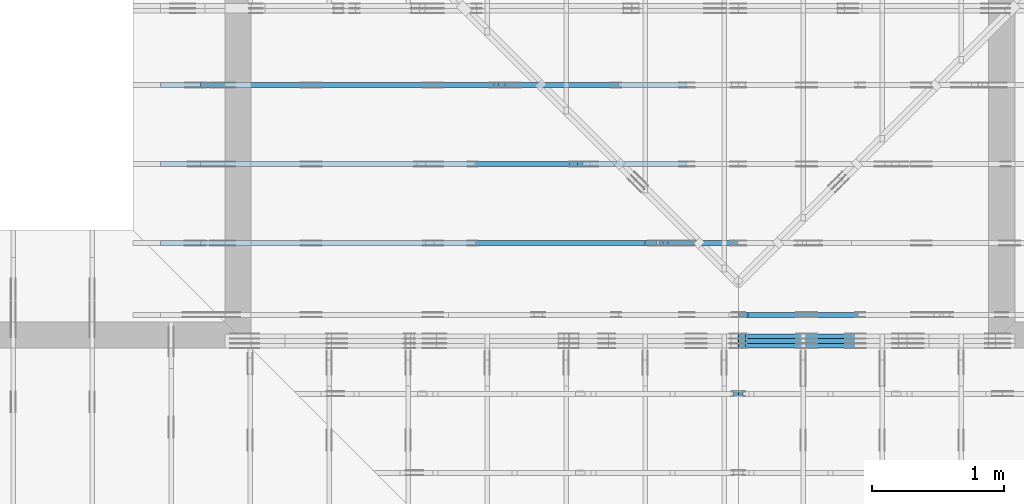
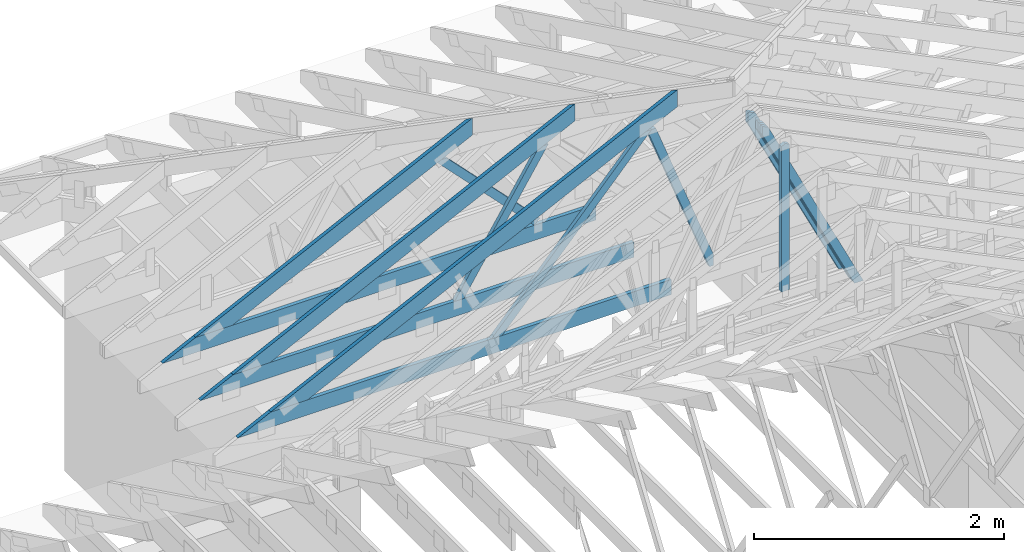
# One storey, part 24 of 159: 15 members, 6 elements without a shape of their own.
"""IFC2X3 building model written with IfcOpenShell, lengths in millimetres."""

from ifc_helpers import new_model, si_unit, frame, origin, origin_with_axes, origin_2d, place, context, project, spatial, faceted_brep, element, aggregate, save


model = new_model("IFC2X3")

# Units and contexts
model_context = context("Model", 3, precision=1e-05, world=origin())
plan_context = context("Plan", 2, precision=1e-05, world=origin_2d())
ifc_project = project(units=[si_unit("LENGTHUNIT", "METRE", prefix="MILLI"), si_unit("AREAUNIT", "SQUARE_METRE"), si_unit("VOLUMEUNIT", "CUBIC_METRE"), si_unit("SOLIDANGLEUNIT", "STERADIAN"), si_unit("PLANEANGLEUNIT", "RADIAN"), si_unit("MASSUNIT", "GRAM"), si_unit("TIMEUNIT", "SECOND"), si_unit("THERMODYNAMICTEMPERATUREUNIT", "DEGREE_CELSIUS"), si_unit("LUMINOUSINTENSITYUNIT", "LUMEN")], contexts=[model_context, plan_context])

# Site, building, storey
site_placement = place(None, origin_with_axes())
site = spatial("IfcSite", under=ifc_project, at=site_placement, CompositionType="ELEMENT")
building_placement = place(site_placement, origin_with_axes())
building = spatial("IfcBuilding", under=site, at=building_placement, Name="Plan 1", CompositionType="ELEMENT")
storey_placement = place(building_placement, origin_with_axes())
storey = spatial("IfcBuildingStorey", under=building, at=storey_placement, Name="Etasje 1", CompositionType="ELEMENT", Elevation=0.0)

# Assembly, members
assembly_1_placement = place(storey_placement, frame((10700.012663101485, 8801.999999990367, 0.0), z_axis=(0.0, -1.0, 6.123031769111886e-17), x_axis=(1.0, 0.0, 0.0)))
assembly_1 = element("IfcElementAssembly", 1, at=assembly_1_placement, inside=storey, Name="T8 (1)", AssemblyPlace="FACTORY", PredefinedType="TRUSS")
member_1_placement = place(assembly_1_placement, frame((3867.1831450672885, 2182.9264166511875, -36.0), z_axis=(0.0, 0.0, 1.0), x_axis=(0.4377636024900682, -0.8990901113542055, 0.0)))
member_1 = element("IfcMember", 2, at=member_1_placement, Name="T8-D14", context=model_context, shape_type="Brep", body=[
    faceted_brep([(2050.832503315577, 73.00014652169102, 36.0), (46.65294485877507, 73.00014652169102, 36.0), (3.151926284772344e-05, 36.50005791443709, 36.0), (70.69479385025807, 0.00011864720727317035, 36.0), (2015.289005817306, 0.00011864720727317035, 36.0), (46.65294485877507, 73.00014652169102, 5.713149269858096e-15), (2050.832503315577, 73.00014652169102, 2.5114625141857073e-13), (2015.289005817306, 0.00011864720727317035, 2.4679357213122545e-13), (70.69479385025807, 0.00011864720727317035, 8.657329373118915e-15), (3.151926284772344e-05, 36.50005791443709, 3.859868955111972e-21), (0.0, 36.50007326104515, 1.9721522630525295e-31), (0.0, 36.50007326104515, 36.0), (46.652844679834985, 73.00007326084416, 36.0), (46.652844679834985, 73.00007326084416, 7.888609052210118e-31), (70.69489161796128, 7.326084413961098e-05, 0.0), (70.69489161796128, 7.32608441431637e-05, 36.0), (7.105427357601002e-15, 36.50007326104515, 36.0), (5.329070518200751e-15, 36.50007326104515, -3.944304526105059e-31), (2015.2890414877363, 7.326084374346175e-05, 8.038005995871943e-29), (2015.2890414877363, 7.326084374566604e-05, 36.0), (70.69489161796128, 7.326084410287039e-05, 36.0), (70.69489161796128, 7.32608441006661e-05, 2.8196742860405922e-30), (2050.832467645144, 73.0000732608413, 2.2274802057917417e-29), (2050.832467645144, 73.0000732608413, 36.0), (2015.2890414877365, 7.326084494252427e-05, 36.0), (2015.2890414877365, 7.326084494252427e-05, 9.903223427570626e-30), (46.65284467983497, 73.00007326084415, 7.888609052210118e-31), (46.65284467983497, 73.00007326084415, 36.0), (2050.832467645144, 73.0000732608418, 36.0), (2050.832467645144, 73.0000732608418, 2.3665827156630354e-29)], [[[0, 1, 2, 3, 4]], [[5, 6, 7, 8, 9]], [[10, 11, 12, 13]], [[14, 15, 16, 17]], [[18, 19, 20, 21]], [[22, 23, 24, 25]], [[26, 27, 28, 29]]]),
])
member_2_placement = place(assembly_1_placement, frame((3867.1831450672885, 2182.9264166511875, -72.0), z_axis=(0.0, 0.0, 1.0), x_axis=(0.4377636024900682, -0.8990901113542055, 0.0)))
member_2 = element("IfcMember", 3, at=member_2_placement, Name="T8-D14", context=model_context, shape_type="Brep", body=[
    faceted_brep([(2050.832503315577, 73.00014652169102, 36.0), (46.65294485877507, 73.00014652169102, 36.0), (3.151926284772344e-05, 36.50005791443709, 36.0), (70.69479385025807, 0.00011864720727317035, 36.0), (2015.289005817306, 0.00011864720727317035, 36.0), (46.65294485877507, 73.00014652169102, 5.713149269858096e-15), (2050.832503315577, 73.00014652169102, 2.5114625141857073e-13), (2015.289005817306, 0.00011864720727317035, 2.4679357213122545e-13), (70.69479385025807, 0.00011864720727317035, 8.657329373118915e-15), (3.151926284772344e-05, 36.50005791443709, 3.859868955111972e-21), (0.0, 36.50007326104515, 1.9721522630525295e-31), (0.0, 36.50007326104515, 36.0), (46.652844679834985, 73.00007326084416, 36.0), (46.652844679834985, 73.00007326084416, 7.888609052210118e-31), (70.69489161796128, 7.326084413961098e-05, 0.0), (70.69489161796128, 7.32608441431637e-05, 36.0), (7.105427357601002e-15, 36.50007326104515, 36.0), (5.329070518200751e-15, 36.50007326104515, -3.944304526105059e-31), (2015.2890414877363, 7.326084374346175e-05, 8.038005995871943e-29), (2015.2890414877363, 7.326084374566604e-05, 36.0), (70.69489161796128, 7.326084410287039e-05, 36.0), (70.69489161796128, 7.32608441006661e-05, 2.8196742860405922e-30), (2050.832467645144, 73.0000732608413, 2.2274802057917417e-29), (2050.832467645144, 73.0000732608413, 36.0), (2015.2890414877365, 7.326084494252427e-05, 36.0), (2015.2890414877365, 7.326084494252427e-05, 9.903223427570626e-30), (46.65284467983497, 73.00007326084415, 7.888609052210118e-31), (46.65284467983497, 73.00007326084415, 36.0), (2050.832467645144, 73.0000732608418, 36.0), (2050.832467645144, 73.0000732608418, 2.3665827156630354e-29)], [[[0, 1, 2, 3, 4]], [[5, 6, 7, 8, 9]], [[10, 11, 12, 13]], [[14, 15, 16, 17]], [[18, 19, 20, 21]], [[22, 23, 24, 25]], [[26, 27, 28, 29]]]),
])
member_3_placement = place(assembly_1_placement, frame((3867.1831450672885, 2182.9264166511875, -108.0), z_axis=(0.0, 0.0, 1.0), x_axis=(0.4377636024900682, -0.8990901113542055, 0.0)))
member_3 = element("IfcMember", 4, at=member_3_placement, Name="T8-D14", context=model_context, shape_type="Brep", body=[
    faceted_brep([(2050.832503315577, 73.00014652169102, 36.0), (46.65294485877507, 73.00014652169102, 36.0), (3.151926284772344e-05, 36.50005791443709, 36.0), (70.69479385025807, 0.00011864720727317035, 36.0), (2015.289005817306, 0.00011864720727317035, 36.0), (46.65294485877507, 73.00014652169102, 5.713149269858096e-15), (2050.832503315577, 73.00014652169102, 2.5114625141857073e-13), (2015.289005817306, 0.00011864720727317035, 2.4679357213122545e-13), (70.69479385025807, 0.00011864720727317035, 8.657329373118915e-15), (3.151926284772344e-05, 36.50005791443709, 3.859868955111972e-21), (0.0, 36.50007326104515, 1.9721522630525295e-31), (0.0, 36.50007326104515, 36.0), (46.652844679834985, 73.00007326084416, 36.0), (46.652844679834985, 73.00007326084416, 7.888609052210118e-31), (70.69489161796128, 7.326084413961098e-05, 0.0), (70.69489161796128, 7.32608441431637e-05, 36.0), (7.105427357601002e-15, 36.50007326104515, 36.0), (5.329070518200751e-15, 36.50007326104515, -3.944304526105059e-31), (2015.2890414877363, 7.326084374346175e-05, 8.038005995871943e-29), (2015.2890414877363, 7.326084374566604e-05, 36.0), (70.69489161796128, 7.326084410287039e-05, 36.0), (70.69489161796128, 7.32608441006661e-05, 2.8196742860405922e-30), (2050.832467645144, 73.0000732608413, 2.2274802057917417e-29), (2050.832467645144, 73.0000732608413, 36.0), (2015.2890414877365, 7.326084494252427e-05, 36.0), (2015.2890414877365, 7.326084494252427e-05, 9.903223427570626e-30), (46.65284467983497, 73.00007326084415, 7.888609052210118e-31), (46.65284467983497, 73.00007326084415, 36.0), (2050.832467645144, 73.0000732608418, 36.0), (2050.832467645144, 73.0000732608418, 2.3665827156630354e-29)], [[[0, 1, 2, 3, 4]], [[5, 6, 7, 8, 9]], [[10, 11, 12, 13]], [[14, 15, 16, 17]], [[18, 19, 20, 21]], [[22, 23, 24, 25]], [[26, 27, 28, 29]]]),
])
aggregate(assembly_1, [member_1, member_2, member_3])

assembly_2_placement = place(storey_placement, frame((19200.01266310149, 9617.999978540158, 1.1021457184401395e-15), z_axis=(1.2246063538223773e-16, 1.0, 6.123031769111886e-17), x_axis=(-1.0, 1.2246063538223773e-16, 0.0)))
assembly_2 = element("IfcElementAssembly", 5, at=assembly_2_placement, inside=storey, Name="V12 (104)", AssemblyPlace="FACTORY", PredefinedType="TRUSS")
member_4_placement = place(assembly_2_placement, frame((4868.032734113786, 2068.176519268255, -36.00000021758211), z_axis=(0.0, 0.0, 1.0), x_axis=(0.8987940462991668, -0.4383711467890778, 0.0)))
member_4 = element("IfcMember", 6, at=member_4_placement, Name="V12-O21/", context=model_context, shape_type="Brep", body=[
    faceted_brep([(112.2381202116849, 6.724413664116469e-06, 36.000003247793494), (40.05369626058609, 148.0000015411115, 36.000000217582105), (2.6318052736229447e-05, 148.00000121991977, 7.105427357601002e-15), (72.18445026915151, 6.403221963324768e-06, 3.030211367160973e-06), (3871.5515959304867, 1.5418238112585308e-06, 2.175821123273636e-07), (3871.5515959304867, 1.5418238054692165e-06, 36.00000021758211), (112.2381193679862, 1.5418244960210919e-06, 36.00000021758211), (72.18445039215612, 1.5418245091679028e-06, 2.175821123273636e-07), (2.6403477022540756e-05, 148.00000154111422, 2.1758211232736357e-07), (40.0536953793071, 148.00000154111422, 36.00000021758211), (4174.996608434727, 148.00000154111396, 36.00000021758211), (4174.996608434727, 148.00000154111396, 2.1758211232736357e-07), (4174.996582031251, 148.00000154094096, 2.1758211232736357e-07), (4174.996582031251, 148.00000154094096, 36.00000021758211), (3871.551610318119, 1.1368683772161603e-12, 36.00000021758211), (3871.551610318119, 1.1368683772161603e-12, 2.1758211232736357e-07), (4174.996567354337, 148.0000015409405, 36.00000021758211), (40.053696260586094, 148.0000015409405, 36.00000021758211), (112.23812161459091, 1.5411114873131737e-06, 36.00000021758211), (3871.5514989949606, 1.5411114873131737e-06, 36.00000021758211), (0.0, 148.0000015411133, 2.1758211232736357e-07), (4174.996582031251, 148.0000015411133, 2.1758262360009773e-07), (3871.5516052246094, 1.5409400475618895e-06, 2.1758258644003306e-07), (72.18457031250045, 1.5409400475618895e-06, 2.1758212116713192e-07)], [[[0, 1, 2, 3]], [[4, 5, 6, 7]], [[8, 9, 10, 11]], [[12, 13, 14, 15]], [[16, 17, 18, 19]], [[20, 21, 22, 23]]]),
])
member_5_placement = place(assembly_2_placement, frame((8988.818704318255, 371.0000000000006, -36.0), z_axis=(0.0, 0.0, 1.0), x_axis=(-1.0, 1.2246063538223773e-16, 0.0)))
member_5 = element("IfcMember", 7, at=member_5_placement, Name="V12-U38", context=model_context, shape_type="Brep", body=[
    faceted_brep([(3997.637551974505, 148.00000000000108, 36.0), (0.00034494325518608093, 148.00000000000108, 36.0), (303.4446808807552, 6.252776074688882e-13, 36.0), (3997.637551974505, 6.252776074688882e-13, 36.0), (0.00034494325518608093, 148.00000000000108, 4.224197020090484e-20), (3997.637551974505, 148.00000000000108, 4.895532346426913e-13), (3997.637551974505, 6.252776074688882e-13, 4.895532346426913e-13), (303.4446808807552, 6.252776074688882e-13, 3.7160028424017644e-14), (303.4449685551226, 6.536993168992922e-13, 0.0), (303.4449685551226, 6.536993168992922e-13, 36.0), (7.105427357601002e-15, 148.00000000000057, 36.0), (7.105427357601002e-15, 148.00000000000057, 1.5777218104420236e-30), (3997.6374086365104, -5.769123819085074e-14, 3.532452842419802e-30), (3997.6374086365104, -5.5486946753970464e-14, 36.0), (303.4449685551226, 6.231027834009684e-13, 36.0), (303.4449685551226, 6.208984919640881e-13, 2.681346335650138e-31), (3997.6374086365104, 148.0, 0.0), (3997.6374086365104, 148.0, 36.0), (3997.6374086365104, 0.0, 36.0), (3997.6374086365104, 0.0, 0.0), (0.0, 148.0000000000006, 0.0), (0.0, 148.0000000000006, 36.0), (3997.6374086365104, 148.00000000000034, 36.0), (3997.6374086365104, 148.00000000000034, 2.208810534618833e-29)], [[[0, 1, 2, 3]], [[4, 5, 6, 7]], [[8, 9, 10, 11]], [[12, 13, 14, 15]], [[16, 17, 18, 19]], [[20, 21, 22, 23]]]),
])
member_6_placement = place(assembly_2_placement, frame((5172.22314453125, 1895.8059082031255, -36.0), z_axis=(0.0, 0.0, 1.0), x_axis=(0.6709049751771838, -0.7415433327072009, 0.0)))
member_6 = element("IfcMember", 8, at=member_6_placement, Name="V12-D12", context=model_context, shape_type="Brep", body=[
    faceted_brep([(2122.306225441494, 73.0000895030862, 36.0), (123.98934672968244, 73.0000895030862, 36.0), (33.023069788921475, 36.50000839691529, 36.0), (0.0, 0.0, 36.0), (2056.260085863651, 0.0, 36.0), (123.98934672968244, 73.0000895030862, 1.5183814181145492e-14), (2122.306225441494, 73.0000895030862, 2.59898968843244e-13), (2056.260085863651, 0.0, 2.5181091662599743e-13), (0.0, 0.0, 0.0), (33.023069788921475, 36.50000839691529, 4.044026108623303e-15), (33.02320456071221, 36.500081109854364, -1.972152263052529e-31), (33.02320456071221, 36.500081109854364, 36.0), (123.98927520760074, 73.00008110883482, 36.0), (123.98927520760074, 73.00008110883482, -1.972152263052529e-31), (0.00014236790548476308, 8.110883481789386e-05, -1.9612474370588213e-31), (0.00014236790548639765, 8.110883481641501e-05, 36.0), (33.02320456071219, 36.50008110985437, 36.0), (33.02320456071219, 36.50008110985437, 4.829269335550994e-31), (2056.260093463095, 8.11088326160008e-05, -3.211175444344668e-29), (2056.260093463095, 8.110883261820509e-05, 36.0), (0.00014236790548238787, 8.110883482224716e-05, 36.0), (0.00014236790548238787, 8.110883482004287e-05, -2.256949153578792e-36), (2122.3062178468645, 73.0000811088313, 9.108869167412563e-30), (2122.3062178468645, 73.0000811088313, 36.0), (2056.260093463095, 8.110883186418505e-05, 36.0), (2056.260093463095, 8.110883186418505e-05, 2.112393974685405e-29), (123.98927520760071, 73.00008110883482, -7.888609052210118e-31), (123.98927520760071, 73.00008110883482, 36.0), (2122.306217846864, 73.00008110883114, 36.0), (2122.306217846864, 73.00008110883115, -2.3665827156630354e-30)], [[[0, 1, 2, 3, 4]], [[5, 6, 7, 8, 9]], [[10, 11, 12, 13]], [[14, 15, 16, 17]], [[18, 19, 20, 21]], [[22, 23, 24, 25]], [[26, 27, 28, 29]]]),
])
member_7_placement = place(assembly_2_placement, frame((5138.050199035864, 1908.6302075253413, -36.0), z_axis=(0.0, 0.0, 1.0), x_axis=(-0.3513501152812546, -0.9362441436355419, 0.0)))
member_7 = element("IfcMember", 9, at=member_7_placement, Name="V12-D23", context=model_context, shape_type="Brep", body=[
    faceted_brep([(1614.943768565292, 73.00000993266622, 36.0), (18.83348092261849, 73.00000993266622, 36.0), (6.797350579290651e-06, 36.50003913609362, 36.0), (13.697514563114964, 0.00023204812987387413, 36.0), (1523.575705642223, 0.00023204812987387413, 36.0), (1628.6412763310566, 36.50003913609362, 36.0), (18.83348092261849, 73.00000993266622, 2.3063600402431134e-15), (1614.943768565292, 73.00000993266622, 1.9776704000509112e-13), (1628.6412763310566, 36.50003913609362, 1.9944444550923979e-13), (1523.575705642223, 0.00023204812987387413, 1.8657804896588783e-13), (13.697514563114964, 0.00023204812987387413, 1.677406336556513e-15), (6.797350579290651e-06, 36.50003913609362, 8.324078708557548e-22), (7.105427357601002e-15, 36.50020284638502, -6.9159902460455675e-31), (8.881784197001252e-15, 36.50020284638502, 36.0), (18.833515854002158, 73.00020284638865, 36.0), (18.833515854002158, 73.00020284638865, -1.2125939293229986e-30), (13.697580161053338, 0.0002028463886736276, 9.860761315262648e-32), (13.69758016105334, 0.00020284638867451577, 36.0), (1.2434497875801753e-14, 36.500202846385044, 36.0), (1.0658141036401503e-14, 36.500202846385044, -6.902532920683853e-31), (1523.5756432061971, 0.00020284638572123836, -4.192448261450648e-29), (1523.5756432061971, 0.00020284638572344265, 36.0), (13.697580161053338, 0.0002028463886828758, 36.0), (13.697580161053338, 0.0002028463886806715, -3.7691803181150353e-31), (1628.6412763304238, 36.50020284638845, -4.417621069237666e-29), (1628.6412763304238, 36.50020284638845, 36.0), (1523.5756432061971, 0.00020284638571865798, 36.0), (1523.5756432061971, 0.00020284638571865798, -4.417621069237666e-29), (1614.94369616937, 73.00020284638578, -2.524354896707238e-29), (1614.94369616937, 73.00020284638578, 36.0), (1628.6412763304238, 36.500202846387594, 36.0), (1628.6412763304238, 36.500202846387594, -3.7865323450608567e-29), (18.833515854002144, 73.00020284638867, 0.0), (18.833515854002144, 73.00020284638867, 36.0), (1614.9436961693702, 73.00020284638609, 36.0), (1614.9436961693702, 73.00020284638609, 8.67746995743113e-30)], [[[0, 1, 2, 3, 4, 5]], [[6, 7, 8, 9, 10, 11]], [[12, 13, 14, 15]], [[16, 17, 18, 19]], [[20, 21, 22, 23]], [[24, 25, 26, 27]], [[28, 29, 30, 31]], [[32, 33, 34, 35]]]),
])
aggregate(assembly_2, [member_4, member_5, member_6, member_7])

# Assembly, member
assembly_3_placement = place(storey_placement, frame((10000.012663278096, 9072.000080051337, 1.1021457184401395e-15), z_axis=(9.811600543477555e-09, 1.0, 6.123031769111886e-17), x_axis=(-1.0, 9.811600543477555e-09, 0.0)))
assembly_3 = element("IfcElementAssembly", 10, at=assembly_3_placement, inside=storey, Name="T9 (79)", AssemblyPlace="FACTORY", PredefinedType="TRUSS")
member_8_placement = place(assembly_3_placement, frame((-4644.001488190774, 2220.465713450832, -36.0), z_axis=(0.0, 0.0, 1.0), x_axis=(-0.44001794709498976, -0.8979889789047029, 0.0)))
member_8 = element("IfcMember", 11, at=member_8_placement, Name="T9-D6", context=model_context, shape_type="Brep", body=[
    faceted_brep([(2011.5435371806107, 98.00006286187272, 36.0), (99.99930369278604, 98.00006286187272, 36.0), (3.148066070934874e-05, 49.00004685636395, 36.0), (62.95466142410328, 3.602707602112787e-05, 36.0), (2059.5639332975634, 3.602707602112787e-05, 36.0), (99.99930369278604, 98.00006286187272, 1.224597826799993e-14), (2011.5435371806107, 98.00006286187272, 2.463348996621715e-13), (2059.5639332975634, 3.602707602112787e-05, 2.522155078819603e-13), (62.95466142410328, 3.602707602112787e-05, 7.709467838269339e-15), (3.148066070934874e-05, 49.00004685636395, 3.855141712719493e-21), (0.0, 49.000031430724455, 0.0), (0.0, 49.00003143072445, 36.0), (99.99923925161968, 98.0000314309273, 36.0), (99.99923925161968, 98.0000314309273, 7.888609052210118e-31), (62.95466421156628, 3.143092725110819e-05, 1.2715458089324881e-30), (62.95466421156628, 3.143092725110819e-05, 36.0), (1.0658141036401503e-14, 49.000031430724455, 36.0), (1.0658141036401503e-14, 49.000031430724455, -6.033762740314717e-31), (2059.563917896294, 3.143092334318367e-05, 1.7398996690814695e-29), (2059.563917896294, 3.1430923345387964e-05, 36.0), (62.954664211566296, 3.143092725883752e-05, 36.0), (62.954664211566296, 3.143092725663323e-05, 5.318350217131518e-31), (2011.5435525818932, 98.00003143092158, -3.7865323450608567e-29), (2011.5435525818932, 98.00003143092158, 36.0), (2059.5639178962933, 3.143092339996656e-05, 36.0), (2059.5639178962933, 3.143092339996656e-05, -3.7865323450608567e-29), (99.99923925161967, 98.00003143092725, -7.888609052210118e-31), (99.99923925161967, 98.00003143092725, 36.0), (2011.543552581894, 98.00003143092162, 36.0), (2011.543552581894, 98.00003143092162, -1.1832913578315177e-29)], [[[0, 1, 2, 3, 4]], [[5, 6, 7, 8, 9]], [[10, 11, 12, 13]], [[14, 15, 16, 17]], [[18, 19, 20, 21]], [[22, 23, 24, 25]], [[26, 27, 28, 29]]]),
])
aggregate(assembly_3, [member_8])

# Assembly, members
assembly_4_placement = place(storey_placement, frame((19200.01266310149, 10817.999978540158, 1.1021457184401395e-15), z_axis=(1.2246063538223773e-16, 1.0, 6.123031769111886e-17), x_axis=(-1.0, 1.2246063538223773e-16, 0.0)))
assembly_4 = element("IfcElementAssembly", 12, at=assembly_4_placement, inside=storey, Name="V10 (59)", AssemblyPlace="FACTORY", PredefinedType="TRUSS")
member_9_placement = place(assembly_4_placement, frame((6068.032721425419, 1482.8974191777506, -36.0000002175517), z_axis=(0.0, 0.0, 1.0), x_axis=(0.8987940462991668, -0.4383711467890778, 0.0)))
member_9 = element("IfcMember", 13, at=member_9_placement, Name="V10-O41", context=model_context, shape_type="Brep", body=[
    faceted_brep([(112.23813432918358, 6.723730159308161e-06, 36.000003247706644), (40.053710378035234, 148.00000154040345, 36.000000217551715), (4.043547323107077e-05, 148.0000012191972, 2.1316282072803006e-14), (72.18446438662258, 6.402523972326435e-06, 3.0301558595624556e-06), (2536.4292955948113, 1.541111021394059e-06, 2.1755170109827304e-07), (2536.4292955948113, 1.5411114792338798e-06, 36.0000002175517), (112.23813348543717, 1.5411119245358648e-06, 36.0000002175517), (72.1844645096071, 1.5411114740535406e-06, 2.1755170109827304e-07), (4.052093117934419e-05, 148.00000154039617, 2.1755170109827304e-07), (40.05370949676217, 148.00000154039526, 36.000000217551694), (2839.874308099056, 148.0000015403951, 36.000000217551694), (2839.874308099056, 148.000001540396, 2.1755170109827304e-07), (2839.8742675781245, 148.0000015409404, 2.1755170109827304e-07), (2839.8742675781245, 148.0000015409404, 36.0000002175517), (2536.4292958649926, 2.2737367544323206e-13, 36.0000002175517), (2536.4292958649926, 2.2737367544323206e-13, 2.1755170109827304e-07), (2839.8742670186584, 148.00000154094005, 36.0000002175517), (40.05371037803525, 148.00000154094005, 36.0000002175517), (112.23813573203824, 1.5404029909404926e-06, 36.0000002175517), (2536.4291986592843, 1.5404029909404926e-06, 36.0000002175517), (0.0, 148.00000154039617, 2.1755170109827304e-07), (2839.874267578125, 148.00000154039617, 2.1755204887108027e-07), (2536.4292907714835, 1.5409400475618895e-06, 2.175520117110156e-07), (72.18457031250091, 1.5409400475618895e-06, 2.175517099380414e-07)], [[[0, 1, 2, 3]], [[4, 5, 6, 7]], [[8, 9, 10, 11]], [[12, 13, 14, 15]], [[16, 17, 18, 19]], [[20, 21, 22, 23]]]),
])
member_10_placement = place(assembly_4_placement, frame((8988.818704318255, 371.0000000000004, -36.0), z_axis=(0.0, 0.0, 1.0), x_axis=(-1.0, 1.2246063538223773e-16, 0.0)))
member_10 = element("IfcMember", 14, at=member_10_placement, Name="V10-U38", context=model_context, shape_type="Brep", body=[
    faceted_brep([(3997.637551974505, 148.00000000000085, 36.0), (0.00034494325518608093, 148.00000000000085, 36.0), (303.4446808807552, 3.979039320256561e-13, 36.0), (3997.637551974505, 3.979039320256561e-13, 36.0), (0.00034494325518608093, 148.00000000000085, 4.224197020090484e-20), (3997.637551974505, 148.00000000000085, 4.895532346426913e-13), (3997.637551974505, 3.979039320256561e-13, 4.895532346426913e-13), (303.4446808807552, 3.979039320256561e-13, 3.7160028424017644e-14), (303.4449685532599, 3.268496584496461e-13, 4.733165431326071e-30), (303.4449685532599, 3.268496584496461e-13, 36.0), (2.1316282072803006e-14, 148.00000000093172, 36.0), (2.1316282072803006e-14, 148.00000000093172, -1.5777218104420236e-30), (3997.6374086346477, -3.037416336246341e-13, 1.8598196722855774e-29), (3997.6374086346477, -3.015373421877538e-13, 36.0), (303.44496855325997, 3.770523879671851e-13, 36.0), (303.44496855325997, 3.748480965303048e-13, 1.4117161320145299e-30), (3997.6374086346477, 148.0, 0.0), (3997.6374086346477, 148.0, 36.0), (3997.6374086346477, 0.0, 36.0), (3997.6374086346477, 0.0, 0.0), (0.0, 148.0000000009317, 0.0), (0.0, 148.0000000009317, 36.0), (3997.6374086346477, 148.00000000000028, 36.0), (3997.6374086346477, 148.00000000000028, 1.735493991486226e-29)], [[[0, 1, 2, 3]], [[4, 5, 6, 7]], [[8, 9, 10, 11]], [[12, 13, 14, 15]], [[16, 17, 18, 19]], [[20, 21, 22, 23]]]),
])
member_11_placement = place(assembly_4_placement, frame((6403.5444552779045, 1344.501464975561, -36.00000000000001), z_axis=(0.0, 0.0, 1.0), x_axis=(-0.6960143876980472, -0.7180278351967371, 0.0)))
member_11 = element("IfcMember", 15, at=member_11_placement, Name="V10-D40", context=model_context, shape_type="Brep", body=[
    faceted_brep([(1285.037122572886, 72.9999876513325, 36.0), (4.934555181534961e-05, 72.9999876513325, 36.0), (11.93588863777859, 36.49986515567707, 36.0), (47.316733296021084, 0.0, 36.0), (1282.7635559142982, 0.0, 36.0), (4.934555181534961e-05, 72.9999876513325, 6.042887628594847e-21), (1285.037122572886, 72.9999876513325, 1.5736646252003812e-13), (1282.7635559142982, 0.0, 1.5708804010244359e-13), (47.316733296021084, 0.0, 5.794437223642625e-15), (11.93588863777859, 36.49986515567707, 1.461676506433998e-15), (11.935754755142629, 36.50002076891861, -1.9721522630525295e-31), (11.93575475514263, 36.50002076891861, 36.0), (1.4210854715202004e-14, 73.0000207690373, 36.0), (1.0658141036401503e-14, 73.0000207690373, -7.888609052210118e-31), (47.316730123507114, 2.0769037739398755e-05, 3.944304526105059e-31), (47.316730123507114, 2.0769037739398755e-05, 36.0), (11.935754755142627, 36.5000207689186, 36.0), (11.935754755142625, 36.5000207689186, 0.0), (1282.763648850574, 2.0769035336725107e-05, -1.9514410306023407e-29), (1282.763648850574, 2.0769035338929398e-05, 36.0), (47.316730123507114, 2.0769037760464403e-05, 36.0), (47.316730123507114, 2.076903775826011e-05, -7.198193259802675e-31), (1285.0370904700176, 73.00002076903456, 0.0), (1285.0370904700176, 73.00002076903456, 36.0), (1282.763648850574, 2.0769035018020077e-05, 36.0), (1282.763648850574, 2.0769035018020077e-05, 1.262177448353619e-29), (0.0, 73.00002076903729, 0.0), (0.0, 73.00002076903729, 36.0), (1285.0370904700176, 73.00002076903465, 36.0), (1285.0370904700176, 73.00002076903465, 5.5220263365470826e-30)], [[[0, 1, 2, 3, 4]], [[5, 6, 7, 8, 9]], [[10, 11, 12, 13]], [[14, 15, 16, 17]], [[18, 19, 20, 21]], [[22, 23, 24, 25]], [[26, 27, 28, 29]]]),
])
aggregate(assembly_4, [member_9, member_10, member_11])

assembly_5_placement = place(storey_placement, frame((19200.01266310149, 10217.999978540158, 1.1021457184401395e-15), z_axis=(1.2246063538223773e-16, 1.0, 6.123031769111886e-17), x_axis=(-1.0, 1.2246063538223773e-16, 0.0)))
assembly_5 = element("IfcElementAssembly", 16, at=assembly_5_placement, inside=storey, Name="V11 (60)", AssemblyPlace="FACTORY", PredefinedType="TRUSS")
member_12_placement = place(assembly_5_placement, frame((5468.032757768089, 1775.5369545917638, -36.00000021758189), z_axis=(0.0, 0.0, 1.0), x_axis=(0.8987940462991668, -0.4383711467890778, 0.0)))
member_12 = element("IfcMember", 17, at=member_12_placement, Name="V11-O31/", context=model_context, shape_type="Brep", body=[
    faceted_brep([(112.23809389363032, 6.724883856890074e-06, 36.00000324779534), (40.053669942533844, 148.00000154158266, 36.00000021758188), (2.4868995751603507e-14, 148.00000122039006, -2.1316282072803006e-14), (72.18442395109696, 6.403691486411844e-06, 3.030213946431104e-06), (3203.990534456185, 1.542291422892e-06, 2.175818920591155e-07), (3203.990534456185, 1.5422914250962915e-06, 36.00000021758189), (112.23809304993574, 1.5422919930232442e-06, 36.00000021758189), (72.18442407410566, 1.5422919981764493e-06, 2.175818920591155e-07), (8.541883289581165e-08, 148.00000154158988, 2.175818920591155e-07), (40.053669061248, 148.0000015415908, 36.00000021758189), (3507.435302819793, 148.00000154159056, 36.00000021758189), (3507.435302819793, 148.00000154158965, 2.175818920591155e-07), (3507.435391428314, 148.00000154093982, 2.175818920591155e-07), (3507.435391428314, 148.00000154093982, 36.00000021758189), (3203.990419715182, -4.547473508864641e-13, 36.00000021758189), (3203.990419715182, -4.547473508864641e-13, 2.175818920591155e-07), (3507.4355058800347, 148.0000015409396, 36.00000021758189), (40.053669942533816, 148.0000015409396, 36.00000021758189), (112.23809529653772, 1.541582605568692e-06, 36.00000021758189), (3203.990437520658, 1.541582605568692e-06, 36.00000021758189), (8.869393877830589e-05, 148.0000015415908, 2.1758189205912634e-07), (3507.435391428314, 148.0000015415908, 2.175823215818821e-07), (3203.9904146216722, 1.5409400475618895e-06, 2.1758228442181743e-07), (72.18441486581287, 1.5409400475618895e-06, 2.175819008988648e-07)], [[[0, 1, 2, 3]], [[4, 5, 6, 7]], [[8, 9, 10, 11]], [[12, 13, 14, 15]], [[16, 17, 18, 19]], [[20, 21, 22, 23]]]),
])
member_13_placement = place(assembly_5_placement, frame((8988.818704316393, 371.0000000000007, -36.0), z_axis=(0.0, 0.0, 1.0), x_axis=(-1.0, 1.2246063538223773e-16, 0.0)))
member_13 = element("IfcMember", 18, at=member_13_placement, Name="V11-U38", context=model_context, shape_type="Brep", body=[
    faceted_brep([(3997.6375519726425, 148.00000000000114, 36.0), (0.0003449413925409317, 148.00000000000114, 36.0), (303.44468087889254, 6.821210263296962e-13, 36.0), (3997.6375519726425, 6.821210263296962e-13, 36.0), (0.0003449413925409317, 148.00000000000114, 4.2241742100196373e-20), (3997.6375519726425, 148.00000000000114, 4.895532346424632e-13), (3997.6375519726425, 6.821210263296962e-13, 4.895532346424632e-13), (303.44468087889254, 6.821210263296962e-13, 3.7160028423789543e-14), (303.44496855325986, 4.973799150320701e-13, 1.262177448353619e-29), (303.44496855325986, 4.973799150320701e-13, 36.0), (1.4210854715202004e-14, 148.0000000000007, 36.0), (1.4210854715202004e-14, 148.0000000000007, -1.5777218104420236e-30), (3997.6374086346477, 3.821360667628595e-15, -2.339831276912468e-31), (3997.6374086346477, 6.025652104508874e-15, 36.0), (303.44496855325997, 6.846153822594478e-13, 36.0), (303.44496855325997, 6.824110908225676e-13, -1.77607410494279e-32), (3997.6374086346477, 148.0, 0.0), (3997.6374086346477, 148.0, 36.0), (3997.6374086346477, 0.0, 36.0), (3997.6374086346477, 0.0, 0.0), (0.0, 148.00000000000065, 0.0), (0.0, 148.00000000000065, 36.0), (3997.6374086346477, 148.0000000000004, 36.0), (3997.6374086346477, 148.0000000000004, 2.524354896707238e-29)], [[[0, 1, 2, 3]], [[4, 5, 6, 7]], [[8, 9, 10, 11]], [[12, 13, 14, 15]], [[16, 17, 18, 19]], [[20, 21, 22, 23]]]),
])
member_14_placement = place(assembly_5_placement, frame((5778.253417968751, 1603.1662597656252, -36.0), z_axis=(0.0, 0.0, 1.0), x_axis=(0.5346520927158749, -0.8450722689536887, 0.0)))
member_14 = element("IfcMember", 19, at=member_14_placement, Name="V11-D32", context=model_context, shape_type="Brep", body=[
    faceted_brep([(1504.245094465062, 72.99991117244463, 36.0), (82.23806248865185, 72.99991117244463, 36.0), (23.09237573890414, 36.49985967898738, 36.0), (0.0, 0.0, 36.0), (1458.0603429872538, 0.0, 36.0), (82.23806248865185, 72.99991117244463, 1.0070925384964476e-14), (1504.245094465062, 72.99991117244463, 1.8421081003880572e-13), (1458.0603429872538, 0.0, 1.7855499602786256e-13), (0.0, 0.0, 0.0), (23.09237573890414, 36.49985967898738, 2.8279070054715724e-15), (23.09249053478994, 36.500051496969704, -9.084854283158222e-31), (23.09249053478994, 36.500051496969704, 36.0), (82.23793533471509, 73.0000514950161, 36.0), (82.23793533471509, 73.0000514950161, -1.517083361824292e-30), (2.601771848279007e-05, 5.149501612320898e-05, -1.9922748455476458e-33), (2.6017718484652858e-05, 5.149501612203045e-05, 36.0), (23.092490534789935, 36.50005149696972, 36.0), (23.09249053478993, 36.50005149696972, 1.7805227037837399e-31), (1458.0602542113122, 5.149501844542914e-05, 8.056538557688363e-29), (1458.0602542113122, 5.149501844763343e-05, 36.0), (2.6017718482762575e-05, 5.149501612543064e-05, 36.0), (2.6017718482762575e-05, 5.149501612322635e-05, 1.504632769052528e-36), (1504.245183242982, 73.00005149501897, -9.953396529279946e-30), (1504.245183242982, 73.00005149501897, 36.0), (1458.060254211312, 5.1495019761205185e-05, 36.0), (1458.060254211312, 5.1495019761205185e-05, -1.0219585145057083e-29), (82.23793533471508, 73.00005149501612, 0.0), (82.23793533471508, 73.00005149501612, 36.0), (1504.2451832429822, 73.00005149501888, 36.0), (1504.2451832429822, 73.00005149501888, 1.5777218104420236e-30)], [[[0, 1, 2, 3, 4]], [[5, 6, 7, 8, 9]], [[10, 11, 12, 13]], [[14, 15, 16, 17]], [[18, 19, 20, 21]], [[22, 23, 24, 25]], [[26, 27, 28, 29]]]),
])
aggregate(assembly_5, [member_12, member_13, member_14])

# Assembly, member
assembly_6_placement = place(storey_placement, frame((11246.01259527543, 8436.00006782605, 727.7147722720857), z_axis=(0.0, -1.0, 6.123031769111886e-17), x_axis=(1.0, 0.0, 0.0)))
assembly_6 = element("IfcElementAssembly", 20, at=assembly_6_placement, inside=storey, Name="Tr1 (1)", AssemblyPlace="FACTORY", PredefinedType="TRUSS")
member_15_placement = place(assembly_6_placement, frame((3390.500067826055, 89.22082903095922, -36.0), z_axis=(0.0, 0.0, 1.0), x_axis=(-8.269481020090064e-16, 1.0, 0.0)))
member_15 = element("IfcMember", 21, at=member_15_placement, Name="Tr1-D33", context=model_context, shape_type="Brep", body=[
    faceted_brep([(1419.7971153049784, 73.00006782605351, 36.0), (3.7937478651883794e-06, 73.00006782605351, 36.0), (3.7937478083449605e-06, 6.782605487387627e-05, 36.0), (1419.7971153049784, 6.782605487387627e-05, 36.0), (1437.5993613987284, 36.50006782605351, 36.0), (3.7937478651883794e-06, 73.00006782605351, 4.645847740509769e-22), (1419.7971153049784, 73.00006782605351, 1.7386925685411589e-13), (1437.5993613987284, 36.50006782605351, 1.7604933122198747e-13), (1419.7971153049784, 6.782605487387627e-05, 1.7386925685411589e-13), (3.7937478083449605e-06, 6.782605487387627e-05, 4.645847670898957e-22), (1.0658141036401504e-11, 1.3642420526593924e-12, -8.96831017167883e-44), (1.0660345327838385e-11, 1.3642420526593928e-12, 36.0), (3.594401252400423e-15, 73.00000000000091, 36.0), (1.3901098155201442e-15, 73.00000000000091, -8.511686562981172e-32), (1419.797076450769, -1.5759494914150645e-13, 9.649588802450159e-30), (1419.797076450769, -1.5539065770462617e-13, 36.0), (1.0658141036401503e-11, 1.3664463440962714e-12, 36.0), (1.0658141036401503e-11, 1.3642420526593911e-12, 6.726232628759122e-44), (1437.5993159334234, 36.500000000000455, 2.728660023783791e-29), (1437.5993159334234, 36.500000000000455, 36.0), (1419.7970764507695, -1.1368683772161603e-13, 36.0), (1419.7970764507695, -1.1368683772161603e-13, 1.4539686620130402e-29), (1419.7970764526049, 72.99999999999932, -3.7865323450608567e-29), (1419.7970764526049, 72.99999999999932, 36.0), (1437.5993159334228, 36.50000000000034, 36.0), (1437.5993159334228, 36.50000000000034, -2.524354896707238e-29), (0.0, 73.00000000000091, 0.0), (0.0, 73.00000000000091, 36.0), (1419.797076452605, 72.99999999999956, 36.0), (1419.797076452605, 72.99999999999956, 7.888609052210118e-31)], [[[0, 1, 2, 3, 4]], [[5, 6, 7, 8, 9]], [[10, 11, 12, 13]], [[14, 15, 16, 17]], [[18, 19, 20, 21]], [[22, 23, 24, 25]], [[26, 27, 28, 29]]]),
])
aggregate(assembly_6, [member_15])

save(model, "model.ifc")
